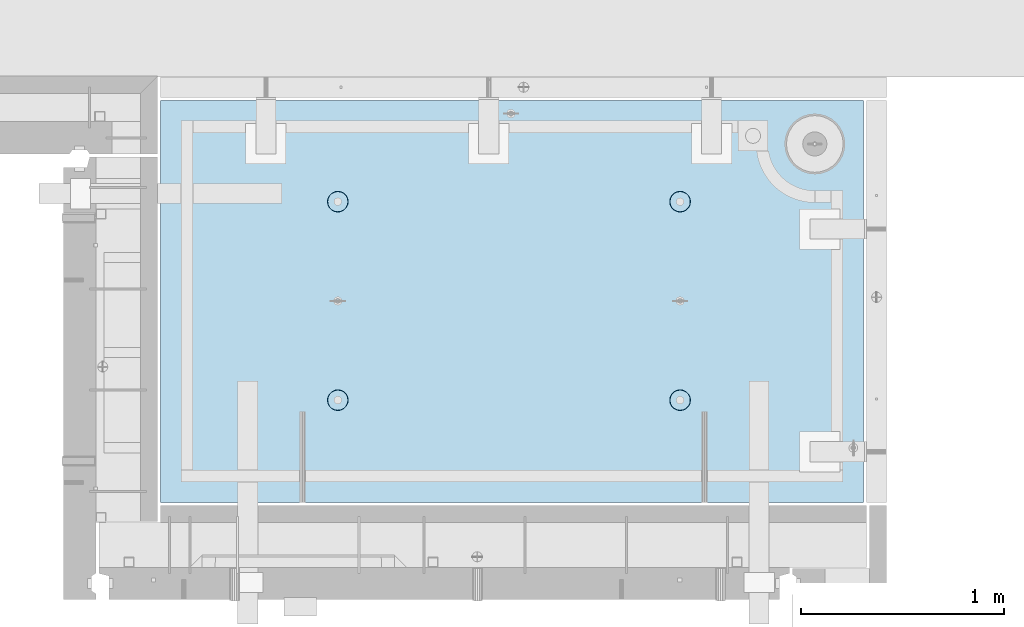
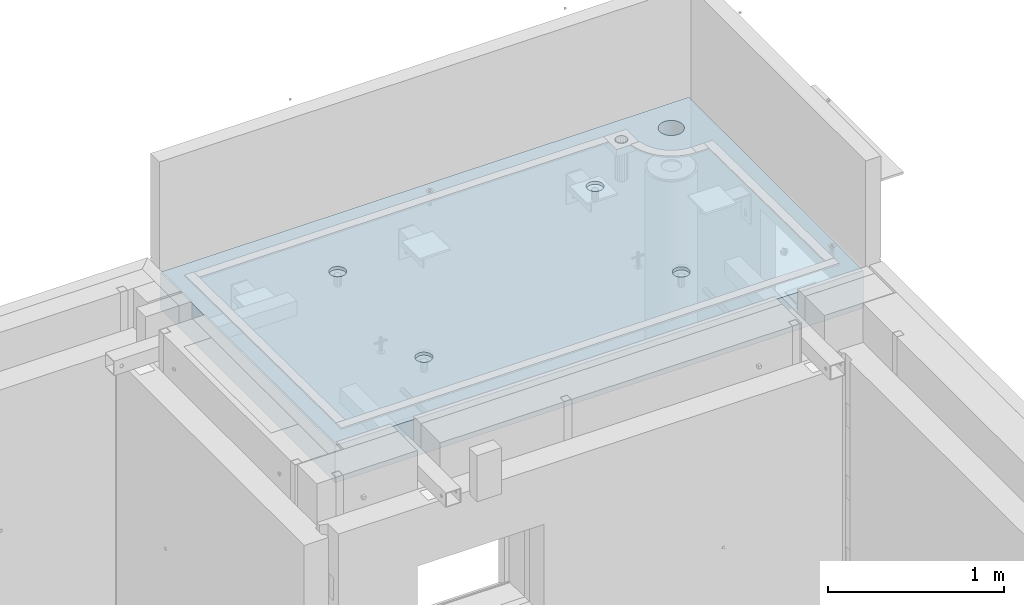
# One storey, part 152 of 264: 1 slab, 1 element without a shape of its own.
"""IFC2X3 building model written with IfcOpenShell, lengths in millimetres."""

from ifc_helpers import new_model, si_unit, frame, origin_with_axes, place, context, subcontext, project, spatial, faceted_brep, material, type_object, element, aggregate, save


model = new_model("IFC2X3")

# Units and contexts
model_context = context("Model", 3, precision=1e-05, world=origin_with_axes())
body_context = subcontext(model_context, "Body", "Model", "MODEL_VIEW")
ifc_project = project(units=[si_unit("LENGTHUNIT", "METRE", prefix="MILLI"), si_unit("AREAUNIT", "SQUARE_METRE"), si_unit("VOLUMEUNIT", "CUBIC_METRE"), si_unit("MASSUNIT", "GRAM", prefix="KILO"), si_unit("TIMEUNIT", "SECOND"), si_unit("PLANEANGLEUNIT", "RADIAN"), si_unit("SOLIDANGLEUNIT", "STERADIAN"), si_unit("THERMODYNAMICTEMPERATUREUNIT", "DEGREE_CELSIUS"), si_unit("LUMINOUSINTENSITYUNIT", "LUMEN")], contexts=[model_context])

# Site, building, storey
site_placement = place(None, origin_with_axes())
site = spatial("IfcSite", under=ifc_project, at=site_placement, CompositionType="ELEMENT")
building_placement = place(site_placement, origin_with_axes())
building = spatial("IfcBuilding", under=site, at=building_placement, CompositionType="ELEMENT")
storey_placement = place(building_placement, origin_with_axes())
storey = spatial("IfcBuildingStorey", under=building, at=storey_placement, Name="K", CompositionType="ELEMENT", Elevation=0.0)

# Assembly, slab
assembly_placement = place(storey_placement, origin_with_axes())
assembly = element("IfcElementAssembly", 1, at=assembly_placement, inside=storey, AssemblyPlace="NOTDEFINED", PredefinedType="REINFORCEMENT_UNIT")
ifc_material = material(Name="CONCRETE/C35/45")
slab_type = type_object("IfcSlabType", PredefinedType="NOTDEFINED")
slab_placement = place(assembly_placement, frame((31779.9998568132, 20899.9965573523, 81575.0), z_axis=(-1.19799915409591e-06, 0.999999999999282, 0.0), x_axis=(0.999999999999282, 1.19800000174933e-06, 0.0)))
slab = element("IfcSlab", 2, at=slab_placement, type_object=slab_type, material=ifc_material, PredefinedType="FLOOR", context=body_context, shape_type="Brep", body=[
    faceted_brep([(2959.65048069304, -130.0, 1795.81551698422), (2959.65048069304, 130.000000000015, 1795.81551698422), (2951.52269537287, 130.000000000015, 1783.6488444481), (2951.52269537287, -130.0, 1783.6488444481), (2939.35761686434, 130.000000000015, 1775.51867349706), (2939.35761686434, -130.0, 1775.51867349706), (2925.00726809365, 130.000000000015, 1772.66274895821), (2925.00726809365, -130.0, 1772.66274895821), (2910.65635957491, 130.000000000015, 1775.51585945357), (2910.65635957491, -130.0, 1775.51585945357), (2898.48968703879, 130.000000000015, 1783.64364477374), (2898.48968703879, -130.0, 1783.64364477374), (2890.35951608775, 130.000000000015, 1795.80872328227), (2890.35951608775, -130.0, 1795.80872328227), (2887.5035915489, 130.000000000015, 1810.15907205296), (2887.5035915489, -130.0, 1810.15907205296), (2890.35670204427, 130.000000000015, 1824.5099805717), (2890.35670204427, -130.0, 1824.5099805717), (2898.48448736444, 130.000000000015, 1836.67665310783), (2898.48448736444, -130.0, 1836.67665310783), (2910.64956587296, 130.000000000015, 1844.80682405887), (2910.64956587296, -130.0, 1844.80682405887), (2924.99991464366, 130.000000000015, 1847.66274859772), (2924.99991464366, -130.0, 1847.66274859772), (2939.3508231624, 130.000000000015, 1844.80963810235), (2939.3508231624, -130.0, 1844.80963810235), (2951.51749569851, 130.000000000015, 1836.68185278219), (2951.51749569851, -130.0, 1836.68185278219), (2959.64766664955, 130.000000000015, 1824.51677427365), (2959.64766664955, -130.0, 1824.51677427365), (2962.50359118841, 130.000000000015, 1810.16642550296), (2962.50359118841, -130.0, 1810.16642550296), (3470.0, -130.0, -2.20097717829049e-09), (0.0, -130.0, -3.63797880709171e-12), (0.0, 130.0, -1.81898940354586e-12), (3470.0, 130.0, -2.20097717829049e-09), (3470.00048828125, -130.0, 1985.00366210938), (3470.00048828125, 130.0, 1985.00366210938), (0.000559809086553287, -130.0, 1985.00366210938), (0.000559809086553287, 130.0, 1985.00366210938), (890.443701616427, -110.0, 1437.44815412734), (904.382128602592, -110.0, 1444.55010256952), (915.443737652884, -110.0, 1455.61166772744), (922.54574140269, -110.0, 1469.55006653296), (924.992946242415, -110.0, 1485.00091139648), (922.545802711662, -110.0, 1500.4517659704), (915.443854269477, -110.0, 1514.39019295657), (904.382289111563, -110.0, 1525.45180200686), (890.44389030604, -110.0, 1532.55380575666), (874.993045442512, -110.0, 1535.00101059639), (859.5421908686, -110.0, 1532.55386706564), (845.603763882435, -110.0, 1525.45191862345), (834.542154832139, -110.0, 1514.39035346554), (827.440151082337, -110.0, 1500.45195466001), (824.992946242612, -110.0, 1485.00110979649), (827.440089773365, -110.0, 1469.55025522257), (834.542038215546, -110.0, 1455.61182823641), (845.603603373464, -110.0, 1444.55021918611), (859.542002178987, -110.0, 1437.44821543631), (874.992847042511, -110.0, 1435.00101059658), (923.678013579975, -130.0, 1500.81964109834), (926.183422432889, -130.0, 1485.00090903458), (916.406971127264, -130.0, 1515.08993539371), (905.082035370349, -130.0, 1526.41491608806), (890.811769926597, -130.0, 1533.68601516524), (874.993047804415, -130.0, 1536.19148678686), (859.174315740653, -130.0, 1533.68607793395), (844.904021445287, -130.0, 1526.41503548124), (833.579040750941, -130.0, 1515.09009972432), (826.307941673756, -130.0, 1500.81983428057), (823.802470052138, -130.0, 1485.00111215839), (826.307878905049, -130.0, 1469.18238009463), (833.578921357763, -130.0, 1454.91208579926), (844.903857114674, -130.0, 1443.58710510491), (859.17412255843, -130.0, 1436.31600602773), (874.992844680608, -130.0, 1433.81053440611), (890.811576744374, -130.0, 1436.31594325902), (905.081871039736, -130.0, 1443.58698571173), (916.406851734086, -130.0, 1454.91192146865), (923.677950811267, -130.0, 1469.1821869124), (890.441757333232, -110.0, 457.456323075745), (904.380184319398, -110.0, 464.558271517926), (915.44179336969, -110.0, 475.619836675844), (922.543797119495, -110.0, 489.558235481371), (924.991001959221, -110.0, 505.009080344891), (922.543858428468, -110.0, 520.459934918807), (915.441909986286, -110.0, 534.398361904972), (904.380344828369, -110.0, 545.459970955264), (890.441946022846, -110.0, 552.56197470507), (874.991101159318, -110.0, 555.009179544795), (859.540246585406, -110.0, 552.562036014042), (845.60181959924, -110.0, 545.460087571857), (834.540210548948, -110.0, 534.398522413943), (827.438206799143, -110.0, 520.46012360842), (824.991001959417, -110.0, 505.009278744892), (827.43814549017, -110.0, 489.558424170984), (834.540093932352, -110.0, 475.619997184815), (845.601659090269, -110.0, 464.558388134519), (859.540057895792, -110.0, 457.456384384717), (874.99090275932, -110.0, 455.009179544992), (923.676069296784, -130.0, 520.827810046754), (926.181478149694, -130.0, 505.009077982988), (916.405026844073, -130.0, 535.098104342116), (905.080091087159, -130.0, 546.423085036466), (890.809825643402, -130.0, 553.694184113647), (874.991103521224, -130.0, 556.199655735272), (859.172371457458, -130.0, 553.694246882354), (844.902077162096, -130.0, 546.423204429644), (833.57709646775, -130.0, 535.098268672729), (826.305997390566, -130.0, 520.828003228977), (823.800525768944, -130.0, 505.009281106795), (826.305934621854, -130.0, 489.190549043033), (833.576977074568, -130.0, 474.920254747667), (844.901912831479, -130.0, 463.595274053321), (859.172178275239, -130.0, 456.32417497614), (874.990900397414, -130.0, 453.818703354518), (890.809632461183, -130.0, 456.324112207432), (905.079926756542, -130.0, 463.595154660143), (916.404907450891, -130.0, 474.920090417054), (923.676006528072, -130.0, 489.19035586081), (2580.44175736364, -110.0, 457.452970243303), (2594.3801843498, -110.0, 464.554918685484), (2605.4417934001, -110.0, 475.616483843402), (2612.54379714991, -110.0, 489.554882648928), (2614.99100198962, -110.0, 505.005727512449), (2612.54385845887, -110.0, 520.456582086365), (2605.44191001669, -110.0, 534.39500907253), (2594.38034485878, -110.0, 545.456618122822), (2580.44194605325, -110.0, 552.558621872628), (2564.99110118972, -110.0, 555.005826712353), (2549.54024661581, -110.0, 552.5586831816), (2535.60181962965, -110.0, 545.456734739415), (2524.54021057935, -110.0, 534.395169581501), (2517.43820682954, -110.0, 520.456770775978), (2514.99100198982, -110.0, 505.00592591245), (2517.43814552058, -110.0, 489.555071338542), (2524.54009396276, -110.0, 475.616644352373), (2535.60165912067, -110.0, 464.555035302077), (2549.5400579262, -110.0, 457.453031552275), (2564.99090278973, -110.0, 455.00582671255), (2613.67606932719, -130.0, 520.824457214312), (2616.1814781801, -130.0, 505.005725150546), (2606.40502687448, -130.0, 535.094751509674), (2595.08009111756, -130.0, 546.419732204024), (2580.80982567381, -130.0, 553.690831281205), (2564.99110355163, -130.0, 556.19630290283), (2549.17237148786, -130.0, 553.690894049912), (2534.9020771925, -130.0, 546.419851597202), (2523.57709649815, -130.0, 535.094915840287), (2516.30599742097, -130.0, 520.824650396535), (2513.80052579935, -130.0, 505.005928274353), (2516.30593465226, -130.0, 489.187196210591), (2523.57697710497, -130.0, 474.916901915225), (2534.90191286189, -130.0, 463.591921220879), (2549.17217830564, -130.0, 456.320822143698), (2564.99090042782, -130.0, 453.815350522076), (2580.80963249159, -130.0, 456.32075937499), (2595.07992678695, -130.0, 463.591801827701), (2606.4049074813, -130.0, 474.916737584612), (2613.67600655848, -130.0, 489.187003028368), (2580.44370158411, -110.0, 1437.44480125841), (2594.38212857028, -110.0, 1444.5467497006), (2605.44373762057, -110.0, 1455.60831485851), (2612.54574137038, -110.0, 1469.54671366404), (2614.9929462101, -110.0, 1484.99755852756), (2612.54580267935, -110.0, 1500.44841310148), (2605.44385423717, -110.0, 1514.38684008764), (2594.38228907925, -110.0, 1525.44844913793), (2580.44389027373, -110.0, 1532.55045288774), (2564.9930454102, -110.0, 1534.99765772746), (2549.54219083629, -110.0, 1532.55051419671), (2535.60376385012, -110.0, 1525.44856575453), (2524.54215479983, -110.0, 1514.38700059661), (2517.44015105002, -110.0, 1500.44860179109), (2514.99294621029, -110.0, 1484.99775692756), (2517.44008974105, -110.0, 1469.54690235365), (2524.54203818323, -110.0, 1455.60847536748), (2535.60360334115, -110.0, 1444.54686631719), (2549.54200214667, -110.0, 1437.44486256739), (2564.9928470102, -110.0, 1434.99765772766), (2613.67801354766, -130.0, 1500.81628822942), (2616.18342240057, -130.0, 1484.99755616566), (2606.40697109495, -130.0, 1515.08658252479), (2595.08203533804, -130.0, 1526.41156321914), (2580.81176989429, -130.0, 1533.68266229632), (2564.9930477721, -130.0, 1536.18813391794), (2549.17431570834, -130.0, 1533.68272506502), (2534.90402141297, -130.0, 1526.41168261231), (2523.57904071863, -130.0, 1515.0867468554), (2516.30794164144, -130.0, 1500.81648141164), (2513.80247001983, -130.0, 1484.99775928947), (2516.30787887274, -130.0, 1469.1790272257), (2523.57892132545, -130.0, 1454.90873293034), (2534.90385708237, -130.0, 1443.58375223599), (2549.17412252611, -130.0, 1436.31265315881), (2564.99284464829, -130.0, 1433.80718153719), (2580.81157671207, -130.0, 1436.3125903901), (2595.08187100743, -130.0, 1443.58363284281), (2606.40685170178, -130.0, 1454.90856859972), (2613.67795077896, -130.0, 1469.17883404348), (3294.95428096498, -130.0, 1732.5017942999), (3283.03535345268, -130.0, 1716.96880935803), (3267.50232121663, -130.0, 1705.0499434807), (3249.41373473417, -130.0, 1697.55744768059), (3230.00230128129, -130.0, 1695.00192316455), (3210.59087796887, -130.0, 1697.55752470514), (3192.50232121678, -130.0, 1705.0500922807), (3176.9693362749, -130.0, 1716.96901979301), (3165.05047039759, -130.0, 1732.50205202906), (3157.55797459747, -130.0, 1750.59063851151), (3155.00245008143, -130.0, 1770.0020719644), (3157.55805162203, -130.0, 1789.41349527681), (3165.05061919758, -130.0, 1807.50205202891), (3176.96954670988, -130.0, 1823.03503697078), (3192.50257894594, -130.0, 1834.95390284811), (3210.5911654284, -130.0, 1842.44639864822), (3230.00259888128, -130.0, 1845.00192316425), (3249.41402219369, -130.0, 1842.44632162367), (3267.50257894579, -130.0, 1834.95375404811), (3283.03556388767, -130.0, 1823.0348265358), (3294.95442976498, -130.0, 1807.50179429975), (3302.44692556509, -130.0, 1789.41320781729), (3305.00245008114, -130.0, 1770.0017743644), (3302.44684854054, -130.0, 1750.59035105199), (3294.95442976498, 130.0, 1807.50179429975), (3302.44692556509, 130.0, 1789.41320781729), (3283.03556388767, 130.0, 1823.0348265358), (3267.50257894579, 130.0, 1834.95375404811), (3249.41402219369, 130.0, 1842.44632162367), (3230.00259888128, 130.0, 1845.00192316425), (3210.5911654284, 130.0, 1842.44639864822), (3192.50257894594, 130.0, 1834.95390284811), (3176.96954670988, 130.0, 1823.03503697078), (3165.05061919758, 130.0, 1807.50205202891), (3157.55805162203, 130.0, 1789.41349527681), (3155.00245008143, 130.0, 1770.0020719644), (3157.55797459747, 130.0, 1750.59063851151), (3165.05047039759, 130.0, 1732.50205202906), (3176.9693362749, 130.0, 1716.96901979301), (3192.50232121678, 130.0, 1705.0500922807), (3210.59087796887, 130.0, 1697.55752470514), (3230.00230128129, 130.0, 1695.00192316455), (3249.41373473417, 130.0, 1697.55744768059), (3267.50232121663, 130.0, 1705.0499434807), (3283.03535345268, 130.0, 1716.96880935803), (3294.95428096498, 130.0, 1732.5017942999), (3302.44684854054, 130.0, 1750.59035105199), (3305.00245008114, 130.0, 1770.0017743644)], [[[0, 1, 2, 3]], [[3, 2, 4, 5]], [[5, 4, 6, 7]], [[7, 6, 8, 9]], [[9, 8, 10, 11]], [[11, 10, 12, 13]], [[13, 12, 14, 15]], [[15, 14, 16, 17]], [[17, 16, 18, 19]], [[19, 18, 20, 21]], [[21, 20, 22, 23]], [[23, 22, 24, 25]], [[25, 24, 26, 27]], [[27, 26, 28, 29]], [[29, 28, 30, 31]], [[31, 30, 1, 0]], [[32, 33, 34, 35]], [[36, 32, 35, 37]], [[38, 36, 37, 39]], [[33, 38, 39, 34]], [[40, 41, 42, 43, 44, 45, 46, 47, 48, 49, 50, 51, 52, 53, 54, 55, 56, 57, 58, 59]], [[60, 45, 44, 61]], [[62, 46, 45, 60]], [[63, 47, 46, 62]], [[64, 48, 47, 63]], [[65, 49, 48, 64]], [[66, 50, 49, 65]], [[67, 51, 50, 66]], [[68, 52, 51, 67]], [[69, 53, 52, 68]], [[70, 54, 53, 69]], [[71, 55, 54, 70]], [[72, 56, 55, 71]], [[73, 57, 56, 72]], [[74, 58, 57, 73]], [[75, 59, 58, 74]], [[76, 40, 59, 75]], [[77, 41, 40, 76]], [[78, 42, 41, 77]], [[79, 43, 42, 78]], [[61, 44, 43, 79]], [[80, 81, 82, 83, 84, 85, 86, 87, 88, 89, 90, 91, 92, 93, 94, 95, 96, 97, 98, 99]], [[100, 85, 84, 101]], [[102, 86, 85, 100]], [[103, 87, 86, 102]], [[104, 88, 87, 103]], [[105, 89, 88, 104]], [[106, 90, 89, 105]], [[107, 91, 90, 106]], [[108, 92, 91, 107]], [[109, 93, 92, 108]], [[110, 94, 93, 109]], [[111, 95, 94, 110]], [[112, 96, 95, 111]], [[113, 97, 96, 112]], [[114, 98, 97, 113]], [[115, 99, 98, 114]], [[116, 80, 99, 115]], [[117, 81, 80, 116]], [[118, 82, 81, 117]], [[119, 83, 82, 118]], [[101, 84, 83, 119]], [[120, 121, 122, 123, 124, 125, 126, 127, 128, 129, 130, 131, 132, 133, 134, 135, 136, 137, 138, 139]], [[140, 125, 124, 141]], [[142, 126, 125, 140]], [[143, 127, 126, 142]], [[144, 128, 127, 143]], [[145, 129, 128, 144]], [[146, 130, 129, 145]], [[147, 131, 130, 146]], [[148, 132, 131, 147]], [[149, 133, 132, 148]], [[150, 134, 133, 149]], [[151, 135, 134, 150]], [[152, 136, 135, 151]], [[153, 137, 136, 152]], [[154, 138, 137, 153]], [[155, 139, 138, 154]], [[156, 120, 139, 155]], [[157, 121, 120, 156]], [[158, 122, 121, 157]], [[159, 123, 122, 158]], [[141, 124, 123, 159]], [[160, 161, 162, 163, 164, 165, 166, 167, 168, 169, 170, 171, 172, 173, 174, 175, 176, 177, 178, 179]], [[180, 165, 164, 181]], [[182, 166, 165, 180]], [[183, 167, 166, 182]], [[184, 168, 167, 183]], [[185, 169, 168, 184]], [[186, 170, 169, 185]], [[187, 171, 170, 186]], [[188, 172, 171, 187]], [[189, 173, 172, 188]], [[190, 174, 173, 189]], [[191, 175, 174, 190]], [[192, 176, 175, 191]], [[193, 177, 176, 192]], [[194, 178, 177, 193]], [[195, 179, 178, 194]], [[196, 160, 179, 195]], [[197, 161, 160, 196]], [[198, 162, 161, 197]], [[199, 163, 162, 198]], [[181, 164, 163, 199]], [[32, 36, 38, 33], [3, 5, 7, 9, 11, 13, 15, 17, 19, 21, 23, 25, 27, 29, 31, 0], [198, 197, 196, 195, 194, 193, 192, 191, 190, 189, 188, 187, 186, 185, 184, 183, 182, 180, 181, 199], [158, 157, 156, 155, 154, 153, 152, 151, 150, 149, 148, 147, 146, 145, 144, 143, 142, 140, 141, 159], [118, 117, 116, 115, 114, 113, 112, 111, 110, 109, 108, 107, 106, 105, 104, 103, 102, 100, 101, 119], [78, 77, 76, 75, 74, 73, 72, 71, 70, 69, 68, 67, 66, 65, 64, 63, 62, 60, 61, 79], [200, 201, 202, 203, 204, 205, 206, 207, 208, 209, 210, 211, 212, 213, 214, 215, 216, 217, 218, 219, 220, 221, 222, 223]], [[220, 224, 225, 221]], [[219, 226, 224, 220]], [[218, 227, 226, 219]], [[217, 228, 227, 218]], [[216, 229, 228, 217]], [[215, 230, 229, 216]], [[214, 231, 230, 215]], [[213, 232, 231, 214]], [[212, 233, 232, 213]], [[211, 234, 233, 212]], [[210, 235, 234, 211]], [[209, 236, 235, 210]], [[208, 237, 236, 209]], [[207, 238, 237, 208]], [[206, 239, 238, 207]], [[205, 240, 239, 206]], [[204, 241, 240, 205]], [[203, 242, 241, 204]], [[202, 243, 242, 203]], [[201, 244, 243, 202]], [[200, 245, 244, 201]], [[223, 246, 245, 200]], [[222, 247, 246, 223]], [[221, 225, 247, 222]], [[37, 35, 34, 39], [26, 24, 22, 20, 18, 16, 14, 12, 10, 8, 6, 4, 2, 1, 30, 28], [224, 226, 227, 228, 229, 230, 231, 232, 233, 234, 235, 236, 237, 238, 239, 240, 241, 242, 243, 244, 245, 246, 247, 225]]]),
])
aggregate(assembly, [slab])

save(model, "model.ifc")
